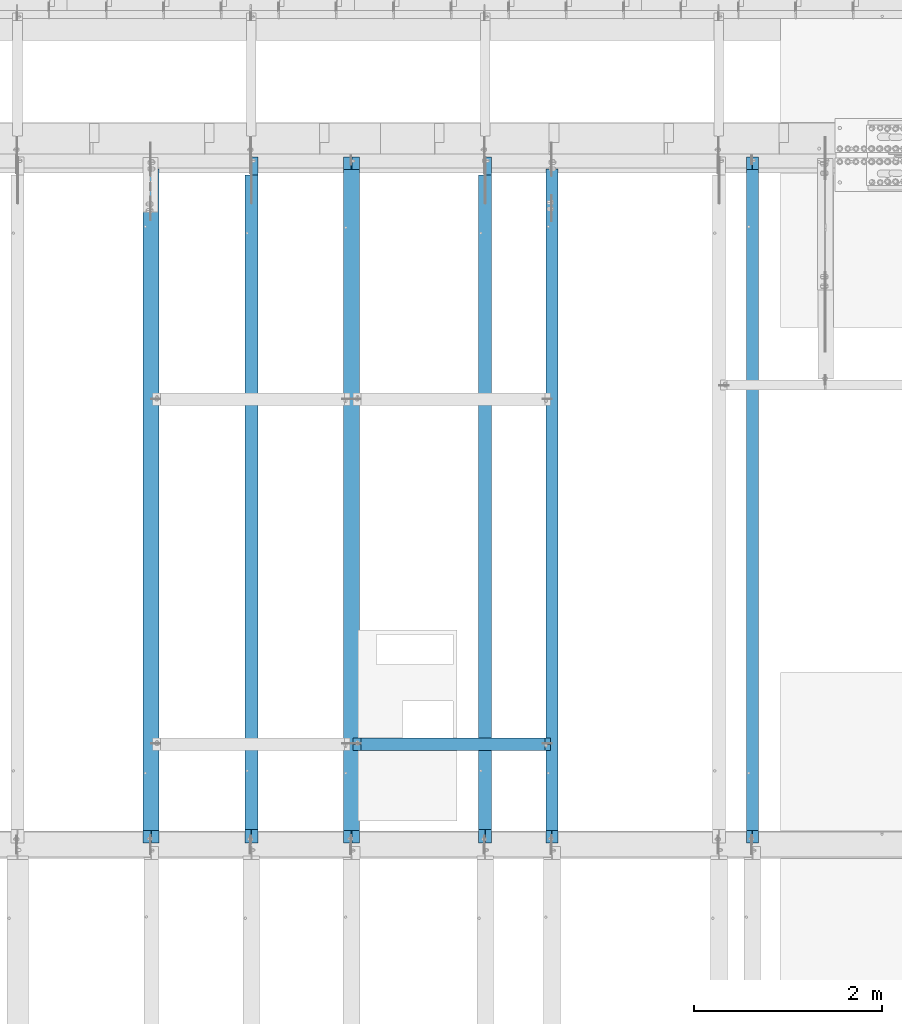
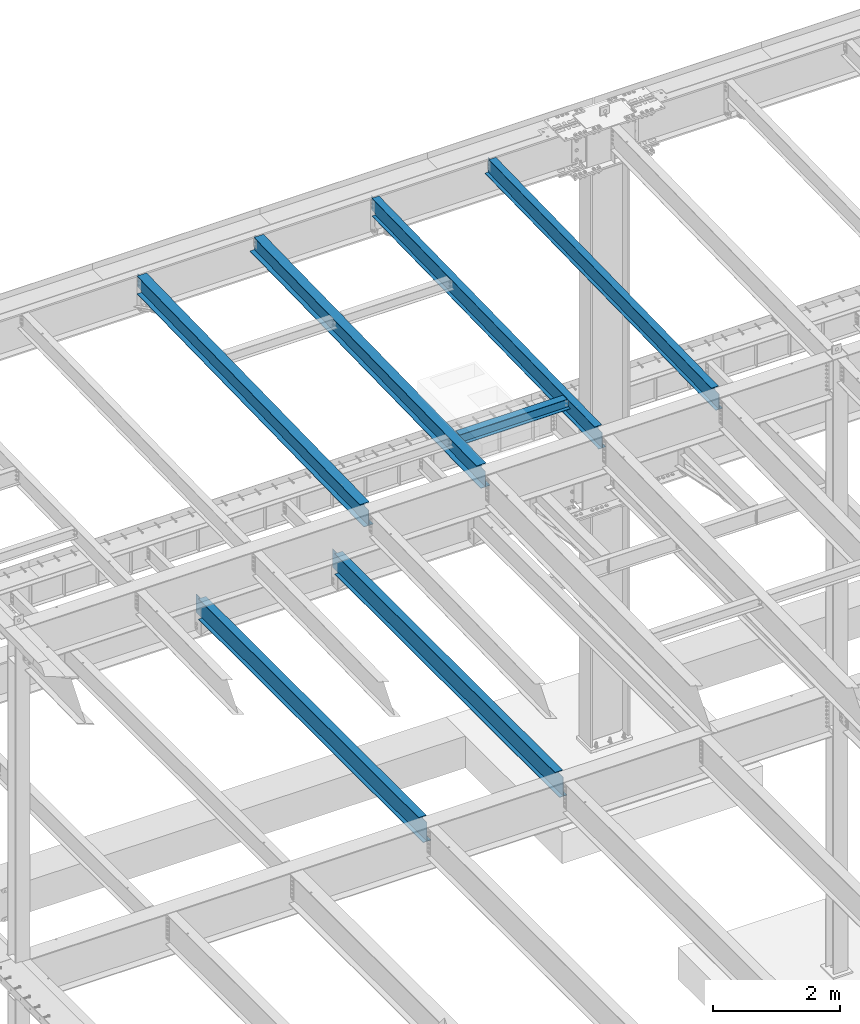
# One storey, part 1126 of 1763: 7 beams, 7 elements without a shape of their own.
"""IFC2X3 building model written with IfcOpenShell, lengths in millimetres."""

from ifc_helpers import new_model, si_unit, frame, origin_with_axes, place, context, subcontext, project, spatial, faceted_brep, material, type_object, element, aggregate, save


model = new_model("IFC2X3")

# Units and contexts
model_context = context("Model", 3, precision=1e-05, world=origin_with_axes())
body_context = subcontext(model_context, "Body", "Model", "MODEL_VIEW")
ifc_project = project(units=[si_unit("LENGTHUNIT", "METRE", prefix="MILLI"), si_unit("AREAUNIT", "SQUARE_METRE"), si_unit("VOLUMEUNIT", "CUBIC_METRE"), si_unit("MASSUNIT", "GRAM", prefix="KILO"), si_unit("TIMEUNIT", "SECOND"), si_unit("PLANEANGLEUNIT", "RADIAN"), si_unit("SOLIDANGLEUNIT", "STERADIAN"), si_unit("THERMODYNAMICTEMPERATUREUNIT", "DEGREE_CELSIUS"), si_unit("LUMINOUSINTENSITYUNIT", "LUMEN")], contexts=[model_context])

# Site, building, storey
site_placement = place(None, origin_with_axes())
site = spatial("IfcSite", under=ifc_project, at=site_placement, CompositionType="ELEMENT")
building_placement = place(site_placement, origin_with_axes())
building = spatial("IfcBuilding", under=site, at=building_placement, Name="Undefined", CompositionType="ELEMENT")
storey_placement = place(building_placement, origin_with_axes())
storey = spatial("IfcBuildingStorey", under=building, at=storey_placement, Name="Undefined", CompositionType="ELEMENT", Elevation=0.0)

# Assembly, beam
assembly_1_placement = place(storey_placement, origin_with_axes())
assembly_1 = element("IfcElementAssembly", 1, at=assembly_1_placement, inside=storey, Name="BEAM", AssemblyPlace="NOTDEFINED", PredefinedType="RIGID_FRAME")
ifc_material = material(Name="STEEL/A992")
beam_type_1 = type_object("IfcBeamType", Name="W8X18", PredefinedType="NOTDEFINED")
beam_1_placement = place(assembly_1_placement, frame((-78775.0426318412, 45872.003125, 11514.3236170495), z_axis=(0.0, 0.0, 1.0), x_axis=(1.0, 0.0, 0.0)))
beam_1 = element("IfcBeam", 2, at=beam_1_placement, type_object=beam_type_1, material=ifc_material, Name="BEAM", ObjectType="W8X18", context=body_context, shape_type="Brep", body=[
    faceted_brep([(1960.42688668017, -3.17500000386644, 68.5472454981009), (1960.42688668019, 3.1749999961321, 68.5472454981009), (1959.56590192083, 3.17499999613938, 69.8358002505338), (1959.56590177228, -3.17500000385917, 69.8358004728379), (1964.54706314833, -3.17500000387372, 65.7942315976234), (1964.54706314833, 3.17499999612482, 65.7942315976234), (1969.40714266637, -3.175000003881, 64.8275016750358), (1969.40714266639, 3.17499999611755, 64.8275016750358), (2015.44464294919, -3.17500000397558, 64.8275016750358), (2015.44464276504, 3.17499999602296, 64.8275016750358), (1958.83938981475, -3.17500000385917, 70.3212402430472), (1958.83938963059, 3.17499999613938, 70.3212402430472), (1956.08637573011, 3.17499999613938, 74.4414167112009), (1956.08637591427, -3.17500000385917, 74.4414167112009), (1955.11964580753, 3.17499999614665, 79.3014962292473), (1955.11964599168, -3.17500000385917, 79.3014962292473), (3.17499685616349, 3.17499999998836, 95.25), (3.17499501466227, 66.6749999999884, 95.25), (1955.11964396603, 66.6749999961467, 95.25), (1955.11964580753, 3.17499999614665, 95.25), (3.17499888181919, -66.6750000000102, 103.1875), (3.17499888181919, -66.6750000000102, 95.25), (1955.11964783318, -66.6750000038592, 95.25), (1955.11964783318, -66.6750000038592, 103.1875), (3.17499501466227, 66.6749999999884, 103.1875), (1955.11964396603, 66.6749999961467, 103.1875), (1955.11964599168, -3.17500000385917, 95.25), (3.17499704031798, -3.17500000001019, 95.25), (3.17499685616349, 3.17499999998836, 79.3014961863064), (3.17499704031798, -3.17500000001019, 79.3014961863064), (2.20826693357958, 3.17499999998836, 74.44141666826), (2.20826711773407, -3.17500000001019, 74.44141666826), (-0.544746966901585, 3.17499999999563, 70.3212402001063), (-0.544746782747097, -3.17500000000291, 70.3212402001063), (-1.27125895427889, 3.17499999999563, 69.83580040995), (-1.27125910282484, -3.17500000000291, 69.8358001876459), (-2.13224382305634, 3.17499999999563, 68.5472454937626), (-2.13224382307089, -3.17500000000291, 68.5472454937626), (-6.25242029121728, 3.17500000001019, 65.7942315932851), (-6.25242029121728, -3.17499999998836, 65.7942315932851), (-11.1124998092564, 3.17500000001746, 64.8275016706975), (-11.112499809271, -3.17499999998108, 64.8275016706975), (-79.3750000920845, 3.17500000014843, 64.8275016706975), (-79.37499990793, -3.17499999985012, 64.8275016706975), (-79.3750000920845, 3.17500000014843, -95.25), (-79.3750019335857, 66.6750000001484, -95.25), (-79.3750019335857, 66.6750000001484, -103.1875), (-79.3749980664288, -66.6749999998501, -103.1875), (-79.3749980664288, -66.6749999998501, -95.25), (-79.37499990793, -3.17499999985012, -95.25), (2015.44464276504, 3.17499999602296, -95.25), (2015.44464092355, 66.674999996023, -95.25), (2015.44464092355, 66.674999996023, -103.1875), (2015.4446447907, -66.6750000039756, -103.1875), (2015.4446447907, -66.6750000039756, -95.25), (2015.44464294919, -3.17500000397558, -95.25)], [[[0, 1, 2, 3]], [[4, 5, 1, 0]], [[6, 7, 5, 4]], [[8, 9, 7, 6]], [[10, 11, 12, 13]], [[13, 12, 14, 15]], [[16, 17, 18, 19]], [[20, 21, 22, 23]], [[24, 20, 23, 25]], [[17, 24, 25, 18]], [[23, 22, 26, 15, 14, 19, 18, 25]], [[21, 27, 26, 22]], [[20, 24, 17, 16, 28, 29, 27, 21]], [[29, 28, 30, 31]], [[31, 30, 32, 33]], [[33, 32, 34, 35]], [[35, 34, 36, 37]], [[37, 36, 38, 39]], [[39, 38, 40, 41]], [[41, 40, 42, 43]], [[44, 45, 46, 47, 48, 49, 43, 42]], [[45, 44, 50, 51]], [[46, 45, 51, 52]], [[47, 46, 52, 53]], [[48, 47, 53, 54]], [[49, 48, 54, 55]], [[4, 0, 3, 10, 13, 15, 26, 27, 29, 31, 33, 35, 37, 39, 41, 43, 49, 55, 8, 6]], [[11, 10, 3, 2]], [[50, 44, 42, 40, 38, 36, 34, 32, 30, 28, 16, 19, 14, 12, 11, 2, 1, 5, 7, 9]], [[55, 54, 53, 52, 51, 50, 9, 8]]]),
])
aggregate(assembly_1, [beam_1])

assembly_2_placement = place(storey_placement, origin_with_axes())
assembly_2 = element("IfcElementAssembly", 3, at=assembly_2_placement, inside=storey, Name="BEAM", AssemblyPlace="NOTDEFINED", PredefinedType="RIGID_FRAME")
beam_type_2 = type_object("IfcBeamType", Name="W14X30", PredefinedType="NOTDEFINED")
beam_2_placement = place(assembly_2_placement, frame((-78870.0658451269, 44809.2449957115, 11419.9762317862), z_axis=(0.0, -0.0206852279954837, 0.999786037781472), x_axis=(0.0, 0.999786037781472, 0.0206852279954825)))
beam_2 = element("IfcBeam", 4, at=beam_2_placement, type_object=beam_type_2, material=ifc_material, Name="BEAM", ObjectType="W14X30", context=body_context, shape_type="Brep", body=[
    faceted_brep([(136.058301248704, -3.17500000000291, 125.15250167846), (136.058301248704, 3.17500000000291, 125.15250167846), (17.9976631131285, 3.17500000000291, 125.152501678482), (17.9976631131285, -3.17500000000291, 125.152501678482), (140.918380766794, -3.17500000000291, 126.119231601042), (140.918380766794, 3.17500000000291, 126.119231601042), (145.038557234977, -3.17500000000291, 128.872245501514), (145.038557234977, 3.17500000000291, 128.872245501514), (147.791571135487, -3.17500000000291, 132.992421969657), (147.791571135487, 3.17500000000291, 132.992421969657), (148.758301058078, -3.17500000000291, 137.85250148769), (148.758301058078, 3.17500000000291, 137.85250148769), (148.758301058078, -85.7250000000058, 176.212499999829), (148.758301058078, 85.7250000000058, 176.212499999829), (148.758301058078, 85.7250000000058, 166.687499999836), (148.758301058078, 3.17500000000291, 166.687499999836), (148.758301058078, -3.17500000000291, 166.687499999836), (148.758301058078, -85.7250000000058, 166.687499999836), (11.9595942215819, -3.17500000000291, -166.687499999876), (11.9595942215819, -85.7250000000058, -166.687499999876), (7288.83204347958, -85.7250000000058, -166.68750000181), (7288.83204347958, -3.17500000000291, -166.68750000181), (11.7625252596117, -85.7250000000058, -176.212499999867), (7288.83204347959, -85.7250000000058, -176.212500001802), (11.7625252596117, 85.7250000000058, -176.212499999867), (7288.83204347959, 85.7250000000058, -176.212500001802), (11.9595942215819, 85.7250000000058, -166.687499999876), (7288.83204347958, 85.7250000000058, -166.68750000181), (11.9595942215819, 3.17500000000291, -166.687499999876), (7288.83204347958, 3.17500000000291, -166.68750000181), (7288.83204347957, 3.17500000000291, 118.802497849627), (7288.83204347957, -3.17500000000291, 118.802497849627), (7178.91184671148, 3.17500000000291, 118.802497849649), (7178.91184671148, -3.17500000000291, 118.802497849649), (7174.05176719339, 3.17500000000291, 119.769227772236), (7174.05176719339, -3.17500000000291, 119.769227772236), (7169.9315907252, 3.17500000000291, 122.522241672708), (7169.9315907252, -3.17500000000291, 122.522241672708), (7167.1785768247, 3.17500000000291, 126.642418140853), (7167.1785768247, -3.17500000000291, 126.642418140853), (7166.21184690211, 3.17500000000291, 131.502497658888), (7166.21184690211, -3.17500000000291, 131.502497658888), (7166.2118469021, -85.7250000000058, 176.212499997964), (7166.21184690209, -85.7250000000058, 166.687499997972), (7166.21184690209, -3.17500000000291, 166.687499997972), (7166.21184690209, 3.17500000000291, 166.687499997972), (7166.21184690209, 85.7250000000058, 166.687499997972), (7166.2118469021, 85.7250000000058, 176.212499997964)], [[[0, 1, 2, 3]], [[4, 5, 1, 0]], [[6, 7, 5, 4]], [[8, 9, 7, 6]], [[10, 11, 9, 8]], [[12, 13, 14, 15, 11, 10, 16, 17]], [[18, 19, 20, 21]], [[19, 22, 23, 20]], [[22, 24, 25, 23]], [[24, 26, 27, 25]], [[26, 28, 29, 27]], [[21, 20, 23, 25, 27, 29, 30, 31]], [[31, 30, 32, 33]], [[33, 32, 34, 35]], [[35, 34, 36, 37]], [[37, 36, 38, 39]], [[39, 38, 40, 41]], [[42, 43, 44, 41, 40, 45, 46, 47]], [[43, 42, 12, 17]], [[44, 43, 17, 16]], [[8, 6, 4, 0, 3, 18, 21, 31, 33, 35, 37, 39, 41, 44, 16, 10]], [[28, 26, 24, 22, 19, 18, 3, 2]], [[45, 40, 38, 36, 34, 32, 30, 29, 28, 2, 1, 5, 7, 9, 11, 15]], [[46, 45, 15, 14]], [[47, 46, 14, 13]], [[42, 47, 13, 12]]]),
])
aggregate(assembly_2, [beam_2])

assembly_3_placement = place(storey_placement, origin_with_axes())
assembly_3 = element("IfcElementAssembly", 5, at=assembly_3_placement, inside=storey, Name="BEAM", AssemblyPlace="NOTDEFINED", PredefinedType="RIGID_FRAME")
beam_3_placement = place(assembly_3_placement, frame((-80996.4087022698, 44809.2449957115, 11419.9762317862), z_axis=(0.0, -0.0206852279954837, 0.999786037781472), x_axis=(0.0, 0.999786037781472, 0.0206852279954825)))
beam_3 = element("IfcBeam", 6, at=beam_3_placement, type_object=beam_type_2, material=ifc_material, Name="BEAM", ObjectType="W14X30", context=body_context, shape_type="Brep", body=[
    faceted_brep([(7162.74075051592, -3.17500000000291, -166.687500001775), (7162.74075051592, -85.7250000000058, -166.687500001775), (7162.74075051592, -85.7250000000058, -176.21250000177), (7162.74075051592, 85.7250000000058, -176.21250000177), (7162.74075051592, 85.7250000000058, -166.687500001775), (7162.74075051592, 3.17500000000291, -166.687500001775), (7162.74075051592, 3.17500000000291, -155.574999838074), (7162.74075051592, -3.17500000000291, -155.574999838074), (7163.70748043853, 3.17500000000291, -150.714920320039), (7163.70748043853, -3.17500000000291, -150.714920320039), (7166.46049433902, 3.17500000000291, -146.594743851896), (7166.46049433902, -3.17500000000291, -146.594743851896), (7170.58067080722, 3.17500000000291, -143.841729951426), (7170.58067080722, -3.17500000000291, -143.841729951426), (7175.4407503253, 3.17500000000291, -142.875000028842), (7175.4407503253, -3.17500000000291, -142.875000028842), (7289.52178484598, -3.17500000000291, -142.875000028926), (7289.52178484598, 3.17500000000291, -142.875000028926), (148.758301058078, 3.17500000000291, 166.687499999836), (148.758301058078, 85.7250000000058, 166.687499999836), (7169.09075051606, 85.7250000000058, 166.68749999797), (7169.09075051606, 3.17500000000291, 166.68749999797), (11.9595942215819, 3.17500000000291, -166.687499999876), (11.9595942215819, 85.7250000000058, -166.687499999876), (11.7625252596117, 85.7250000000058, -176.212499999867), (11.7625252596117, -85.7250000000058, -176.212499999867), (11.9595942215819, -85.7250000000058, -166.687499999876), (11.9595942215819, -3.17500000000291, -166.687499999876), (17.9976631131285, -3.17500000000291, 125.152501678482), (17.9976631131285, 3.17500000000291, 125.152501678482), (136.058301248704, -3.17500000000291, 125.15250167846), (136.058301248704, 3.17500000000291, 125.15250167846), (140.918380766794, -3.17500000000291, 126.119231601042), (140.918380766794, 3.17500000000291, 126.119231601042), (145.038557234977, -3.17500000000291, 128.872245501514), (145.038557234977, 3.17500000000291, 128.872245501514), (147.791571135487, -3.17500000000291, 132.992421969657), (147.791571135487, 3.17500000000291, 132.992421969657), (148.758301058078, -3.17500000000291, 137.85250148769), (148.758301058078, 3.17500000000291, 137.85250148769), (148.758301058078, -85.7250000000058, 176.212499999829), (148.758301058078, 85.7250000000058, 176.212499999829), (148.758301058078, -3.17500000000291, 166.687499999836), (148.758301058078, -85.7250000000058, 166.687499999836), (7169.09075051606, -3.17500000000291, 166.68749999797), (7169.09075051606, -85.7250000000058, 166.68749999797), (7169.09075051606, -85.7250000000058, 176.212499997962), (7169.09075051606, 85.7250000000058, 176.212499997962), (7169.09075051606, -3.17500000000291, 130.174999779601), (7169.09075051606, 3.17500000000291, 130.174999779601), (7170.05748043866, -3.17500000000291, 125.314920261568), (7170.05748043866, 3.17500000000291, 125.314920261568), (7172.81049433917, -3.17500000000291, 121.194743793421), (7172.81049433917, 3.17500000000291, 121.194743793421), (7176.93067080735, -3.17500000000291, 118.441729892949), (7176.93067080735, 3.17500000000291, 118.441729892949), (7181.79075032543, -3.17500000000291, 117.474999970362), (7181.79075032543, 3.17500000000291, 117.474999970362), (7294.90833647314, -3.17500000000291, 117.474999970342), (7294.90833647314, 3.17500000000291, 117.474999970342)], [[[0, 1, 2, 3, 4, 5, 6, 7]], [[7, 6, 8, 9]], [[9, 8, 10, 11]], [[11, 10, 12, 13]], [[13, 12, 14, 15]], [[16, 15, 14, 17]], [[18, 19, 20, 21]], [[22, 23, 24, 25, 26, 27, 28, 29]], [[30, 31, 29, 28]], [[32, 33, 31, 30]], [[34, 35, 33, 32]], [[36, 37, 35, 34]], [[38, 39, 37, 36]], [[40, 41, 19, 18, 39, 38, 42, 43]], [[43, 42, 44, 45]], [[40, 43, 45, 46]], [[41, 40, 46, 47]], [[19, 41, 47, 20]], [[46, 45, 44, 48, 49, 21, 20, 47]], [[50, 51, 49, 48]], [[52, 53, 51, 50]], [[54, 55, 53, 52]], [[56, 57, 55, 54]], [[58, 59, 57, 56]], [[59, 58, 16, 17]], [[12, 10, 8, 6, 5, 22, 29, 31, 33, 35, 37, 39, 18, 21, 49, 51, 53, 55, 57, 59, 17, 14]], [[23, 22, 5, 4]], [[24, 23, 4, 3]], [[25, 24, 3, 2]], [[26, 25, 2, 1]], [[27, 26, 1, 0]], [[58, 56, 54, 52, 50, 48, 44, 42, 38, 36, 34, 32, 30, 28, 27, 0, 7, 9, 11, 13, 15, 16]]]),
])
aggregate(assembly_3, [beam_3])

assembly_4_placement = place(storey_placement, origin_with_axes())
assembly_4 = element("IfcElementAssembly", 7, at=assembly_4_placement, inside=storey, Name="BEAM", AssemblyPlace="NOTDEFINED", PredefinedType="RIGID_FRAME")
beam_type_3 = type_object("IfcBeamType", Name="W16X26", PredefinedType="NOTDEFINED")
beam_4_placement = place(assembly_4_placement, frame((-77452.5700856983, 44805.6, 4994.275), z_axis=(0.0, 0.0, 1.0), x_axis=(0.0, 1.0, 0.0)))
beam_4 = element("IfcBeam", 8, at=beam_4_placement, type_object=beam_type_3, material=ifc_material, Name="BEAM", ObjectType="W16X26", context=body_context, shape_type="Brep", body=[
    faceted_brep([(7104.06248869727, 3.17500000000291, -190.5), (7104.06248869734, 3.17487653380522, -200.025), (7104.06247902929, 69.8499999999985, -200.025), (7104.06247902929, 69.8499999999985, -190.5), (7294.5625, 3.17500000000291, -190.5), (7294.5625, 3.17490415680368, -200.025), (159.543749432261, 3.17500000000291, 190.5), (159.543749432261, 69.8499999999985, 190.5), (7104.0625, 69.8499999999985, 190.5), (7104.0625, 3.17500000000291, 190.5), (159.543749432261, -69.8499999999985, 200.025), (159.543749432261, 69.8499999999985, 200.025), (159.543749432261, 3.17500000000291, 180.715001487732), (159.543749432261, -3.17500000000291, 180.715001487732), (159.543749432261, -3.17500000000291, 190.5), (159.543749432261, -69.8499999999985, 190.5), (158.57701950967, 3.17500000000291, 175.854921969686), (158.57701950967, -3.17500000000291, 175.854921969686), (155.824005609196, 3.17500000000291, 171.734745501532), (155.824005609196, -3.17500000000291, 171.734745501532), (151.703829141043, 3.17500000000291, 168.981731601054), (151.703829141043, -3.17500000000291, 168.981731601054), (146.843749622996, 3.17500000000291, 168.015001678466), (146.843749622996, -3.17500000000291, 168.015001678466), (19.84375, 3.17500000000291, 168.015001678466), (19.84375, -3.17500000000291, 168.015001678466), (19.84375, 3.17500000000291, -190.5), (19.84375, 69.8499999999985, -190.5), (19.84375, 69.8499999999985, -200.025), (19.84375, -69.8499999999985, -200.025), (19.84375, -69.8499999999985, -190.5), (19.84375, -3.17500000000291, -190.5), (7294.5625, -69.8499999999985, -200.025), (7294.5625, -69.8499999999985, -190.5), (7294.5625, -3.17500000000291, -190.5), (7111.90242029122, -3.17500000000291, 156.541729922587), (7107.78224382307, -3.17500000000291, 159.294743823066), (7105.02922992258, -3.17500000000291, 163.414920291219), (7104.0625, -3.17500000000291, 168.274999809265), (7104.0625, -3.17500000000291, 190.5), (7294.5625, -3.17500000000291, 155.575), (7116.76249980927, -3.17500000000291, 155.575), (7104.0625, -69.8499999999985, 190.5), (7104.0625, -69.8499999999985, 200.025), (7104.0625, 69.8499999999985, 200.025), (7104.0625, 3.17500000000291, 168.274999809265), (7105.02922992258, 3.17500000000291, 163.414920291219), (7107.78224382307, 3.17500000000291, 159.294743823066), (7111.90242029122, 3.17500000000291, 156.541729922587), (7116.76249980927, 3.17500000000291, 155.575), (7294.5625, 3.17500000000291, 155.575), (7294.5625, 3.17500000000291, -184.976846570121)], [[[0, 1, 2, 3]], [[4, 5, 1, 0]], [[6, 7, 8, 9]], [[10, 11, 7, 6, 12, 13, 14, 15]], [[13, 12, 16, 17]], [[17, 16, 18, 19]], [[19, 18, 20, 21]], [[21, 20, 22, 23]], [[23, 22, 24, 25]], [[26, 27, 28, 29, 30, 31, 25, 24]], [[30, 29, 32, 33]], [[31, 30, 33, 34]], [[35, 36, 37, 38, 39, 14, 13, 17, 19, 21, 23, 25, 31, 34, 40, 41]], [[15, 14, 39, 42]], [[10, 15, 42, 43]], [[11, 10, 43, 44]], [[7, 11, 44, 8]], [[43, 42, 39, 38, 45, 9, 8, 44]], [[37, 46, 45, 38]], [[36, 47, 46, 37]], [[35, 48, 47, 36]], [[41, 49, 48, 35]], [[40, 50, 49, 41]], [[51, 4, 0, 26, 24, 22, 20, 18, 16, 12, 6, 9, 45, 46, 47, 48, 49, 50]], [[27, 26, 0, 3]], [[28, 27, 3, 2]], [[32, 29, 28, 2, 1, 5]], [[51, 50, 40, 34, 33, 32, 5, 4]]]),
])
aggregate(assembly_4, [beam_4])

assembly_5_placement = place(storey_placement, origin_with_axes())
assembly_5 = element("IfcElementAssembly", 9, at=assembly_5_placement, inside=storey, Name="BEAM", AssemblyPlace="NOTDEFINED", PredefinedType="RIGID_FRAME")
beam_5_placement = place(assembly_5_placement, frame((-79933.2372736984, 44805.6, 4994.275), z_axis=(0.0, 0.0, 1.0), x_axis=(0.0, 1.0, 0.0)))
beam_5 = element("IfcBeam", 10, at=beam_5_placement, type_object=beam_type_3, material=ifc_material, Name="BEAM", ObjectType="W16X26", context=body_context, shape_type="Brep", body=[
    faceted_brep([(7104.06248869727, 3.17500000000291, -190.5), (7104.06248869734, 3.17487653380522, -200.025), (7104.06247902929, 69.8499999999985, -200.025), (7104.06247902929, 69.8499999999985, -190.5), (7294.5625, 3.17500000000291, -190.5), (7294.5625, 3.17490415680368, -200.025), (159.543749432261, 3.17500000000291, 190.5), (159.543749432261, 69.8499999999985, 190.5), (7104.0625, 69.8499999999985, 190.5), (7104.0625, 3.17500000000291, 190.5), (159.543749432261, -69.8499999999985, 200.025), (159.543749432261, 69.8499999999985, 200.025), (159.543749432261, 3.17500000000291, 180.715001487732), (159.543749432261, -3.17500000000291, 180.715001487732), (159.543749432261, -3.17500000000291, 190.5), (159.543749432261, -69.8499999999985, 190.5), (158.57701950967, 3.17500000000291, 175.854921969686), (158.57701950967, -3.17500000000291, 175.854921969686), (155.824005609196, 3.17500000000291, 171.734745501532), (155.824005609196, -3.17500000000291, 171.734745501532), (151.703829141043, 3.17500000000291, 168.981731601054), (151.703829141043, -3.17500000000291, 168.981731601054), (146.843749622996, 3.17500000000291, 168.015001678466), (146.843749622996, -3.17500000000291, 168.015001678466), (19.84375, 3.17500000000291, 168.015001678466), (19.84375, -3.17500000000291, 168.015001678466), (19.84375, 3.17500000000291, -190.5), (19.84375, 69.8499999999985, -190.5), (19.84375, 69.8499999999985, -200.025), (19.84375, -69.8499999999985, -200.025), (19.84375, -69.8499999999985, -190.5), (19.84375, -3.17500000000291, -190.5), (7294.5625, -69.8499999999985, -200.025), (7294.5625, -69.8499999999985, -190.5), (7294.5625, -3.17500000000291, -190.5), (7111.90242029122, -3.17500000000291, 156.541729922587), (7107.78224382307, -3.17500000000291, 159.294743823066), (7105.02922992258, -3.17500000000291, 163.414920291219), (7104.0625, -3.17500000000291, 168.274999809265), (7104.0625, -3.17500000000291, 190.5), (7294.5625, -3.17500000000291, 155.575), (7116.76249980927, -3.17500000000291, 155.575), (7104.0625, -69.8499999999985, 190.5), (7104.0625, -69.8499999999985, 200.025), (7104.0625, 69.8499999999985, 200.025), (7104.0625, 3.17500000000291, 168.274999809265), (7105.02922992258, 3.17500000000291, 163.414920291219), (7107.78224382307, 3.17500000000291, 159.294743823066), (7111.90242029122, 3.17500000000291, 156.541729922587), (7116.76249980927, 3.17500000000291, 155.575), (7294.5625, 3.17500000000291, 155.575), (7294.5625, 3.17500000000291, -184.976846570121)], [[[0, 1, 2, 3]], [[4, 5, 1, 0]], [[6, 7, 8, 9]], [[10, 11, 7, 6, 12, 13, 14, 15]], [[13, 12, 16, 17]], [[17, 16, 18, 19]], [[19, 18, 20, 21]], [[21, 20, 22, 23]], [[23, 22, 24, 25]], [[26, 27, 28, 29, 30, 31, 25, 24]], [[30, 29, 32, 33]], [[31, 30, 33, 34]], [[35, 36, 37, 38, 39, 14, 13, 17, 19, 21, 23, 25, 31, 34, 40, 41]], [[15, 14, 39, 42]], [[10, 15, 42, 43]], [[11, 10, 43, 44]], [[7, 11, 44, 8]], [[43, 42, 39, 38, 45, 9, 8, 44]], [[37, 46, 45, 38]], [[36, 47, 46, 37]], [[35, 48, 47, 36]], [[41, 49, 48, 35]], [[40, 50, 49, 41]], [[51, 4, 0, 26, 24, 22, 20, 18, 16, 12, 6, 9, 45, 46, 47, 48, 49, 50]], [[27, 26, 0, 3]], [[28, 27, 3, 2]], [[32, 29, 28, 2, 1, 5]], [[51, 50, 40, 34, 33, 32, 5, 4]]]),
])
aggregate(assembly_5, [beam_5])

assembly_6_placement = place(storey_placement, origin_with_axes())
assembly_6 = element("IfcElementAssembly", 11, at=assembly_6_placement, inside=storey, Name="BEAM", AssemblyPlace="NOTDEFINED", PredefinedType="RIGID_FRAME")
beam_type_4 = type_object("IfcBeamType", Name="W14X22", PredefinedType="NOTDEFINED")
beam_6_placement = place(assembly_6_placement, frame((-74617.3801308412, 44809.2121579121, 11421.5633921212), z_axis=(0.0, -0.0206852279954837, 0.999786037781472), x_axis=(0.0, 0.999786037781472, 0.0206852279954825)))
beam_6 = element("IfcBeam", 12, at=beam_6_placement, type_object=beam_type_4, material=ifc_material, Name="BEAM", ObjectType="W14X22", context=body_context, shape_type="Brep", body=[
    faceted_brep([(136.091146049795, -3.17500000000291, 123.565001678358), (136.091146049795, 3.17500000000291, 123.565001678358), (17.9976630864912, 3.17500000000291, 123.56500167838), (17.9976630864912, -3.17500000000291, 123.56500167838), (140.951225567893, -3.17500000000291, 124.531731600942), (140.951225567893, 3.17500000000291, 124.531731600942), (145.071402036083, -3.17500000000291, 127.284745501414), (145.071402036083, 3.17500000000291, 127.284745501414), (147.824415936586, -3.17500000000291, 131.404921969557), (147.824415936586, 3.17500000000291, 131.404921969557), (148.791145859177, -3.17500000000291, 136.265001487593), (148.791145859177, 3.17500000000291, 136.265001487593), (148.79114585917, -63.5, 174.624999999827), (148.79114585917, 63.5, 174.624999999827), (148.791145859177, 63.5, 166.687499999833), (148.791145859177, 3.17500000000291, 166.687499999833), (148.791145859177, -3.17500000000291, 166.687499999833), (148.791145859177, -63.5, 166.687499999833), (11.9924390219312, -3.17500000000291, -166.687499999878), (11.9924390219312, -63.5, -166.687499999878), (7289.06195724197, -63.5, -166.687500001812), (7289.06195724197, -3.17500000000291, -166.687500001812), (11.8282148869548, -63.5, -174.624999999871), (7288.89773310699, -63.5, -174.625000001806), (11.8282148869548, 63.5, -174.624999999871), (7288.89773310699, 63.5, -174.625000001806), (11.9924390219312, 63.5, -166.687499999878), (7289.06195724197, 63.5, -166.687500001812), (11.9924390219312, 3.17500000000291, -166.687499999878), (7289.06195724197, 3.17500000000291, -166.687500001812), (7294.93580191941, 3.17500000000291, 117.21499785159), (7294.93580191941, -3.17500000000291, 117.21499785159), (7178.21066392501, 3.17500000000291, 117.214997851612), (7178.21066392501, -3.17500000000291, 117.214997851612), (7173.35058440694, 3.17500000000291, 118.181727774199), (7173.35058440694, -3.17500000000291, 118.181727774199), (7169.23040793875, 3.17500000000291, 120.934741674671), (7169.23040793875, -3.17500000000291, 120.934741674671), (7166.47739403824, 3.17500000000291, 125.054918142816), (7166.47739403824, -3.17500000000291, 125.054918142816), (7165.51066411565, 3.17500000000291, 129.91499766085), (7165.51066411565, -3.17500000000291, 129.91499766085), (7165.51066411565, -63.5, 174.624999997965), (7165.51066411565, -63.5, 166.68749999797), (7165.51066411565, -3.17500000000291, 166.68749999797), (7165.51066411565, 3.17500000000291, 166.68749999797), (7165.51066411565, 63.5, 166.68749999797), (7165.51066411565, 63.5, 174.624999997965)], [[[0, 1, 2, 3]], [[4, 5, 1, 0]], [[6, 7, 5, 4]], [[8, 9, 7, 6]], [[10, 11, 9, 8]], [[12, 13, 14, 15, 11, 10, 16, 17]], [[18, 19, 20, 21]], [[19, 22, 23, 20]], [[22, 24, 25, 23]], [[24, 26, 27, 25]], [[26, 28, 29, 27]], [[21, 20, 23, 25, 27, 29, 30, 31]], [[31, 30, 32, 33]], [[33, 32, 34, 35]], [[35, 34, 36, 37]], [[37, 36, 38, 39]], [[39, 38, 40, 41]], [[42, 43, 44, 41, 40, 45, 46, 47]], [[43, 42, 12, 17]], [[44, 43, 17, 16]], [[8, 6, 4, 0, 3, 18, 21, 31, 33, 35, 37, 39, 41, 44, 16, 10]], [[28, 26, 24, 22, 19, 18, 3, 2]], [[45, 40, 38, 36, 34, 32, 30, 29, 28, 2, 1, 5, 7, 9, 11, 15]], [[46, 45, 15, 14]], [[47, 46, 14, 13]], [[42, 47, 13, 12]]]),
])
aggregate(assembly_6, [beam_6])

assembly_7_placement = place(storey_placement, origin_with_axes())
assembly_7 = element("IfcElementAssembly", 13, at=assembly_7_placement, inside=storey, Name="BEAM", AssemblyPlace="NOTDEFINED", PredefinedType="RIGID_FRAME")
beam_7_placement = place(assembly_7_placement, frame((-76743.7229879841, 44809.2121579121, 11421.5633921212), z_axis=(0.0, -0.0206852279954837, 0.999786037781472), x_axis=(0.0, 0.999786037781472, 0.0206852279954825)))
beam_7 = element("IfcBeam", 14, at=beam_7_placement, type_object=beam_type_4, material=ifc_material, Name="BEAM", ObjectType="W14X22", context=body_context, shape_type="Brep", body=[
    faceted_brep([(7162.77359555585, -3.17500000000291, -166.687500001777), (7162.77359555585, -63.5, -166.687500001777), (7162.77359555585, -63.5, -174.625000001772), (7162.77359555585, 63.5, -174.625000001772), (7162.77359555585, 63.5, -166.687500001777), (7162.77359555585, 3.17500000000291, -166.687500001777), (7162.77359555586, 3.17500000000291, -155.574999838074), (7162.77359555586, -3.17500000000291, -155.574999838074), (7163.74032547845, 3.17500000000291, -150.714920320039), (7163.74032547845, -3.17500000000291, -150.714920320039), (7166.49333937895, 3.17500000000291, -146.594743851894), (7166.49333937895, -3.17500000000291, -146.594743851894), (7170.61351584714, 3.17500000000291, -143.841729951426), (7170.61351584714, -3.17500000000291, -143.841729951426), (7175.47359536523, 3.17500000000291, -142.87500002884), (7175.47359536523, -3.17500000000291, -142.87500002884), (7289.55462988591, -3.17500000000291, -142.875000028898), (7289.55462988591, 3.17500000000291, -142.875000028898), (148.791145859177, 3.17500000000291, 166.687499999833), (148.791145859177, 63.5, 166.687499999833), (7169.123595556, 63.5, 166.68749999797), (7169.123595556, 3.17500000000291, 166.68749999797), (11.9924390219312, 3.17500000000291, -166.687499999878), (11.9924390219312, 63.5, -166.687499999878), (11.8282148869548, 63.5, -174.624999999871), (11.8282148869548, -63.5, -174.624999999871), (11.9924390219312, -63.5, -166.687499999878), (11.9924390219312, -3.17500000000291, -166.687499999878), (17.9976630864912, -3.17500000000291, 123.56500167838), (17.9976630864912, 3.17500000000291, 123.56500167838), (136.091146049795, -3.17500000000291, 123.565001678358), (136.091146049795, 3.17500000000291, 123.565001678358), (140.951225567893, -3.17500000000291, 124.531731600942), (140.951225567893, 3.17500000000291, 124.531731600942), (145.071402036083, -3.17500000000291, 127.284745501414), (145.071402036083, 3.17500000000291, 127.284745501414), (147.824415936586, -3.17500000000291, 131.404921969557), (147.824415936586, 3.17500000000291, 131.404921969557), (148.791145859177, -3.17500000000291, 136.265001487593), (148.791145859177, 3.17500000000291, 136.265001487593), (148.79114585917, -63.5, 174.624999999827), (148.79114585917, 63.5, 174.624999999827), (148.791145859177, -3.17500000000291, 166.687499999833), (148.791145859177, -63.5, 166.687499999833), (7169.123595556, -3.17500000000291, 166.68749999797), (7169.123595556, -63.5, 166.68749999797), (7169.123595556, -63.5, 174.624999997965), (7169.123595556, 63.5, 174.624999997965), (7169.123595556, -3.17500000000291, 142.875000542512), (7169.123595556, 3.17500000000291, 142.875000542512), (7170.0903254786, -3.17500000000291, 138.014921024478), (7170.0903254786, 3.17500000000291, 138.014921024478), (7172.8433393791, -3.17500000000291, 133.894744556334), (7172.8433393791, 3.17500000000291, 133.894744556334), (7176.96351584728, -3.17500000000291, 131.14173065586), (7176.96351584728, 3.17500000000291, 131.14173065586), (7181.82359536537, -3.17500000000291, 130.175000733272), (7181.82359536537, 3.17500000000291, 130.175000733272), (7295.20394014482, -3.17500000000291, 130.17500073325), (7295.20394014482, 3.17500000000291, 130.17500073325)], [[[0, 1, 2, 3, 4, 5, 6, 7]], [[7, 6, 8, 9]], [[9, 8, 10, 11]], [[11, 10, 12, 13]], [[13, 12, 14, 15]], [[16, 15, 14, 17]], [[18, 19, 20, 21]], [[22, 23, 24, 25, 26, 27, 28, 29]], [[30, 31, 29, 28]], [[32, 33, 31, 30]], [[34, 35, 33, 32]], [[36, 37, 35, 34]], [[38, 39, 37, 36]], [[40, 41, 19, 18, 39, 38, 42, 43]], [[43, 42, 44, 45]], [[40, 43, 45, 46]], [[41, 40, 46, 47]], [[19, 41, 47, 20]], [[46, 45, 44, 48, 49, 21, 20, 47]], [[50, 51, 49, 48]], [[52, 53, 51, 50]], [[54, 55, 53, 52]], [[56, 57, 55, 54]], [[58, 59, 57, 56]], [[59, 58, 16, 17]], [[12, 10, 8, 6, 5, 22, 29, 31, 33, 35, 37, 39, 18, 21, 49, 51, 53, 55, 57, 59, 17, 14]], [[23, 22, 5, 4]], [[24, 23, 4, 3]], [[25, 24, 3, 2]], [[26, 25, 2, 1]], [[27, 26, 1, 0]], [[58, 56, 54, 52, 50, 48, 44, 42, 38, 36, 34, 32, 30, 28, 27, 0, 7, 9, 11, 13, 15, 16]]]),
])
aggregate(assembly_7, [beam_7])

save(model, "model.ifc")
